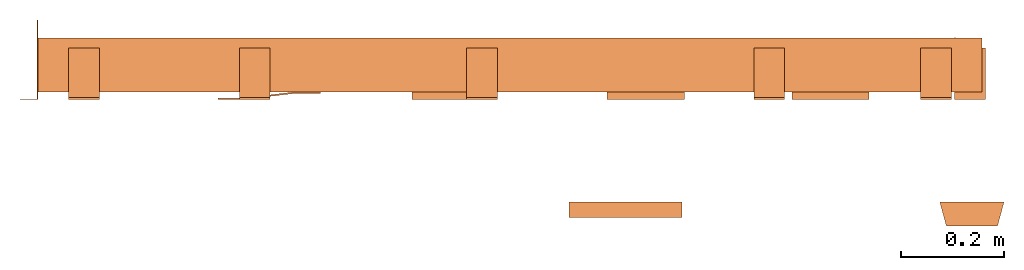
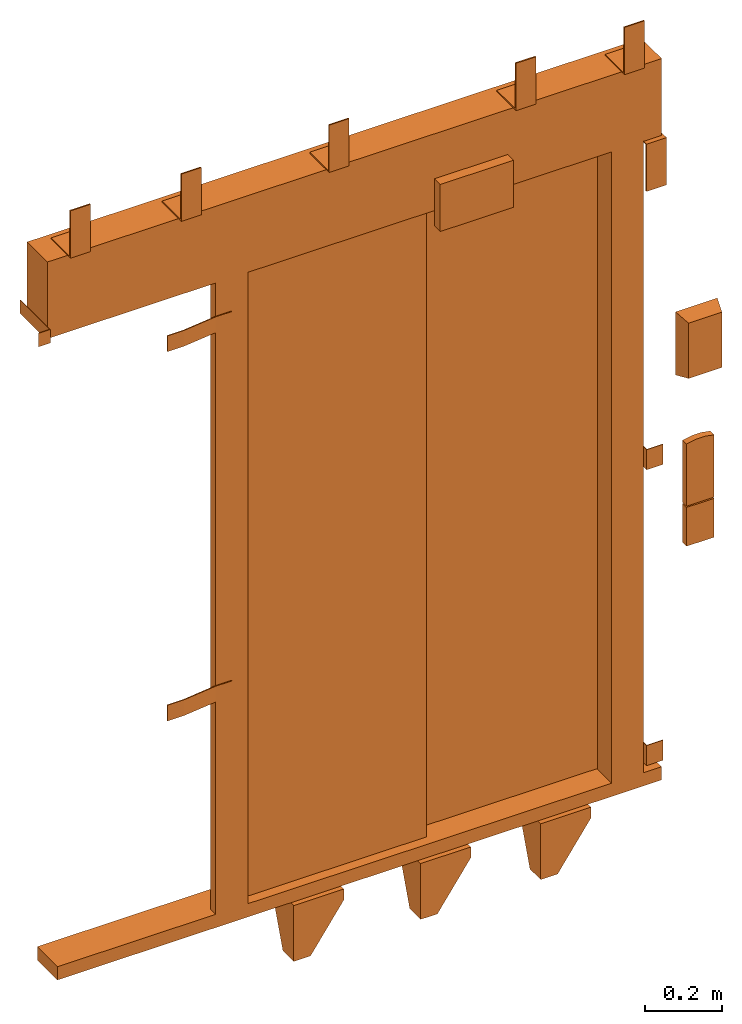
# One storey: 1 proxy.
"""IFC2X3 building model written with IfcOpenShell, lengths in millimetres."""

from ifc_helpers import new_model, entity, si_unit, converted_unit, derived_unit, direction, frame, origin, place, context, subcontext, project, spatial, faceted_brep, source, transform, mapped, material, type_object, type_shapes, element, save


model = new_model("IFC2X3")

# Units and contexts
model_context = context("Model", 3, precision=0.01, world=origin(), true_north=direction((6.12303176911189e-17, 1.0)))
body_context = subcontext(model_context, "Body", "Model", "MODEL_VIEW")
ifc_project = project(units=[si_unit("LENGTHUNIT", "METRE", prefix="MILLI"), si_unit("AREAUNIT", "SQUARE_METRE"), si_unit("VOLUMEUNIT", "CUBIC_METRE"), converted_unit("PLANEANGLEUNIT", "DEGREE", entity("IfcRatioMeasure", 0.0174532925199433), si_unit("PLANEANGLEUNIT", "RADIAN"), dimensions=[0, 0, 0, 0, 0, 0, 0]), si_unit("MASSUNIT", "GRAM", prefix="KILO"), derived_unit("MASSDENSITYUNIT", [(si_unit("MASSUNIT", "GRAM", prefix="KILO"), 1), (si_unit("LENGTHUNIT", "METRE"), -3)]), derived_unit("MOMENTOFINERTIAUNIT", [(si_unit("LENGTHUNIT", "METRE"), 4)]), si_unit("TIMEUNIT", "SECOND"), si_unit("FREQUENCYUNIT", "HERTZ"), si_unit("THERMODYNAMICTEMPERATUREUNIT", "DEGREE_CELSIUS"), derived_unit("THERMALTRANSMITTANCEUNIT", [(si_unit("MASSUNIT", "GRAM", prefix="KILO"), 1), (si_unit("THERMODYNAMICTEMPERATUREUNIT", "KELVIN"), -1), (si_unit("TIMEUNIT", "SECOND"), -3)]), derived_unit("VOLUMETRICFLOWRATEUNIT", [(si_unit("LENGTHUNIT", "METRE"), 3), (si_unit("TIMEUNIT", "SECOND"), -1)]), derived_unit("MASSFLOWRATEUNIT", [(si_unit("MASSUNIT", "GRAM", prefix="KILO"), 1), (si_unit("TIMEUNIT", "SECOND"), -1)]), derived_unit("ROTATIONALFREQUENCYUNIT", [(si_unit("TIMEUNIT", "SECOND"), -1)]), si_unit("ELECTRICCURRENTUNIT", "AMPERE"), si_unit("ELECTRICVOLTAGEUNIT", "VOLT"), si_unit("POWERUNIT", "WATT"), si_unit("FORCEUNIT", "NEWTON", prefix="KILO"), si_unit("ILLUMINANCEUNIT", "LUX"), si_unit("LUMINOUSFLUXUNIT", "LUMEN"), si_unit("LUMINOUSINTENSITYUNIT", "CANDELA"), derived_unit("USERDEFINED", [(si_unit("MASSUNIT", "GRAM", prefix="KILO"), -1), (si_unit("LENGTHUNIT", "METRE"), -2), (si_unit("TIMEUNIT", "SECOND"), 3), (si_unit("LUMINOUSFLUXUNIT", "LUMEN"), 1)]), derived_unit("LINEARVELOCITYUNIT", [(si_unit("LENGTHUNIT", "METRE"), 1), (si_unit("TIMEUNIT", "SECOND"), -1)]), si_unit("PRESSUREUNIT", "PASCAL"), derived_unit("USERDEFINED", [(si_unit("LENGTHUNIT", "METRE"), -2), (si_unit("MASSUNIT", "GRAM", prefix="KILO"), 1), (si_unit("TIMEUNIT", "SECOND"), -2)]), derived_unit("LINEARFORCEUNIT", [(si_unit("MASSUNIT", "GRAM", prefix="KILO"), 1), (si_unit("LENGTHUNIT", "METRE"), 1), (si_unit("TIMEUNIT", "SECOND"), -2), (si_unit("LENGTHUNIT", "METRE"), -1)]), derived_unit("PLANARFORCEUNIT", [(si_unit("MASSUNIT", "GRAM", prefix="KILO"), 1), (si_unit("LENGTHUNIT", "METRE"), 1), (si_unit("TIMEUNIT", "SECOND"), -2), (si_unit("LENGTHUNIT", "METRE"), -2)])], contexts=[model_context])

# Site, building, storey
site_placement = place(None, origin())
site = spatial("IfcSite", under=ifc_project, at=site_placement, CompositionType="ELEMENT")
building_placement = place(site_placement, origin())
building = spatial("IfcBuilding", under=site, at=building_placement, CompositionType="ELEMENT")
storey_placement = place(building_placement, frame((0.0, 0.0, 24000.0)))
storey = spatial("IfcBuildingStorey", under=building, at=storey_placement, CompositionType="ELEMENT", Elevation=24000.0)

# Proxy
ifc_material = material()
building_element_proxy_type = type_object("IfcBuildingElementProxyType", PredefinedType="NOTDEFINED", material=ifc_material)
shared_shape = source(origin(), body_context, "Body", "Brep", [
    faceted_brep([(11.67, 105.0, -47.0), (114.5, 33.0, -47.0), (114.5, 5.0, -47.0), (-31.0, 5.0, -47.0), (-31.0, 105.0, -47.0), (11.67, 105.0, -42.0), (-36.0, 105.0, -42.0), (-36.0, 0.0, -42.0), (114.5, 0.0, -42.0), (114.5, 33.0, -42.0), (-31.0, 105.0, -84.0), (-36.0, 105.0, -84.0), (-36.0, 55.86, -219.0), (-36.0, 0.0, -219.0), (114.5, 0.0, -76.19), (114.5, 5.0, -76.19), (14.5, 5.0, -219.0), (-31.0, 5.0, -219.0), (14.5, 0.0, -219.0), (-31.0, 55.86, -219.0)], [[[0, 1, 2, 3, 4]], [[5, 6, 7, 8, 9]], [[6, 5, 0, 4, 10, 11]], [[6, 11, 12, 13, 7]], [[2, 1, 9, 8, 14, 15]], [[1, 0, 5, 9]], [[15, 16, 17, 3, 2]], [[7, 13, 18, 14, 8]], [[16, 15, 14, 18]], [[18, 13, 12, 19, 17, 16]], [[19, 10, 4, 3, 17]], [[12, 11, 10, 19]]]),
    faceted_brep([(-1180.19, 1.5, 2038.5), (-1180.19, 0.0, 2038.5), (-1145.19, 0.0, 2038.5), (-1145.19, 155.0, 2038.5), (-1146.69, 155.0, 2038.5), (-1146.69, 1.5, 2038.5), (-1180.19, 1.5, 1995.5), (-1146.69, 1.5, 1995.5), (-1146.69, 155.0, 1995.5), (-1145.19, 155.0, 1995.5), (-1145.19, 0.0, 1995.5), (-1180.19, 0.0, 1995.5)], [[[0, 1, 2, 3, 4, 5]], [[6, 7, 8, 9, 10, 11]], [[1, 0, 6, 11]], [[2, 1, 11, 10]], [[3, 2, 10, 9]], [[4, 3, 9, 8]], [[5, 4, 8, 7]], [[0, 5, 7, 6]]]),
    faceted_brep([(-794.09, 3.0, 1895.0), (-794.09, 0.0, 1895.0), (-744.09, 0.0, 1895.0), (-644.09, 12.0, 1895.0), (-594.09, 12.0, 1895.0), (-594.09, 15.0, 1895.0), (-644.09, 15.0, 1895.0), (-744.09, 3.0, 1895.0), (-794.09, 3.0, 1845.0), (-744.09, 3.0, 1845.0), (-644.09, 15.0, 1845.0), (-594.09, 15.0, 1845.0), (-594.09, 12.0, 1845.0), (-644.09, 12.0, 1845.0), (-744.09, 0.0, 1845.0), (-794.09, 0.0, 1845.0)], [[[0, 1, 2, 3, 4, 5, 6, 7]], [[8, 9, 10, 11, 12, 13, 14, 15]], [[1, 0, 8, 15]], [[2, 1, 15, 14]], [[3, 2, 14, 13]], [[4, 3, 13, 12]], [[5, 4, 12, 11]], [[6, 5, 11, 10]], [[7, 6, 10, 9]], [[0, 7, 9, 8]]]),
    faceted_brep([(-794.09, 3.0, 725.0), (-794.09, 0.0, 725.0), (-744.09, 0.0, 725.0), (-644.09, 12.0, 725.0), (-594.09, 12.0, 725.0), (-594.09, 15.0, 725.0), (-644.09, 15.0, 725.0), (-744.09, 3.0, 725.0), (-794.09, 3.0, 675.0), (-744.09, 3.0, 675.0), (-644.09, 15.0, 675.0), (-594.09, 15.0, 675.0), (-594.09, 12.0, 675.0), (-644.09, 12.0, 675.0), (-744.09, 0.0, 675.0), (-794.09, 0.0, 675.0)], [[[0, 1, 2, 3, 4, 5, 6, 7]], [[8, 9, 10, 11, 12, 13, 14, 15]], [[1, 0, 8, 15]], [[2, 1, 15, 14]], [[3, 2, 14, 13]], [[4, 3, 13, 12]], [[5, 4, 12, 11]], [[6, 5, 11, 10]], [[7, 6, 10, 9]], [[0, 7, 9, 8]]]),
    faceted_brep([(641.09, 121.0, 95.0), (641.09, 0.0, 95.0), (691.09, 0.0, 95.0), (691.09, 2.0, 95.0), (643.09, 2.0, 95.0), (643.09, 121.0, 95.0), (641.09, 121.0, 31.0), (643.09, 121.0, 31.0), (643.09, 2.0, 31.0), (691.09, 2.0, 31.0), (691.09, 0.0, 31.0), (641.09, 0.0, 31.0)], [[[0, 1, 2, 3, 4, 5]], [[6, 7, 8, 9, 10, 11]], [[1, 0, 6, 11]], [[2, 1, 11, 10]], [[3, 2, 10, 9]], [[4, 3, 9, 8]], [[5, 4, 8, 7]], [[0, 5, 7, 6]]]),
    faceted_brep([(641.09, 121.0, 1032.0), (641.09, 0.0, 1032.0), (691.09, 0.0, 1032.0), (691.09, 2.0, 1032.0), (643.09, 2.0, 1032.0), (643.09, 121.0, 1032.0), (641.09, 121.0, 968.0), (643.09, 121.0, 968.0), (643.09, 2.0, 968.0), (691.09, 2.0, 968.0), (691.09, 0.0, 968.0), (641.09, 0.0, 968.0)], [[[0, 1, 2, 3, 4, 5]], [[6, 7, 8, 9, 10, 11]], [[1, 0, 6, 11]], [[2, 1, 11, 10]], [[3, 2, 10, 9]], [[4, 3, 9, 8]], [[5, 4, 8, 7]], [[0, 5, 7, 6]]]),
    faceted_brep([(371.77, 105.0, -47.0), (474.59, 33.0, -47.0), (474.59, 5.0, -47.0), (329.09, 5.0, -47.0), (329.09, 105.0, -47.0), (371.77, 105.0, -42.0), (324.09, 105.0, -42.0), (324.09, 0.0, -42.0), (474.59, 0.0, -42.0), (474.59, 33.0, -42.0), (329.09, 105.0, -84.0), (324.09, 105.0, -84.0), (324.09, 55.86, -219.0), (324.09, 0.0, -219.0), (474.59, 0.0, -76.19), (474.59, 5.0, -76.19), (374.59, 5.0, -219.0), (329.09, 5.0, -219.0), (374.59, 0.0, -219.0), (329.09, 55.86, -219.0)], [[[0, 1, 2, 3, 4]], [[5, 6, 7, 8, 9]], [[6, 5, 0, 4, 10, 11]], [[6, 11, 12, 13, 7]], [[2, 1, 9, 8, 14, 15]], [[1, 0, 5, 9]], [[15, 16, 17, 3, 2]], [[7, 13, 18, 14, 8]], [[16, 15, 14, 18]], [[18, 13, 12, 19, 17, 16]], [[19, 10, 4, 3, 17]], [[12, 11, 10, 19]]]),
    faceted_brep([(-368.42, 105.0, -47.0), (-265.59, 33.0, -47.0), (-265.59, 5.0, -47.0), (-411.09, 5.0, -47.0), (-411.09, 105.0, -47.0), (-368.42, 105.0, -42.0), (-416.09, 105.0, -42.0), (-416.09, 0.0, -42.0), (-265.59, 0.0, -42.0), (-265.59, 33.0, -42.0), (-411.09, 105.0, -84.0), (-416.09, 105.0, -84.0), (-416.09, 55.86, -219.0), (-416.09, 0.0, -219.0), (-265.59, 0.0, -76.19), (-265.59, 5.0, -76.19), (-365.59, 5.0, -219.0), (-411.09, 5.0, -219.0), (-365.59, 0.0, -219.0), (-411.09, 55.86, -219.0)], [[[0, 1, 2, 3, 4]], [[5, 6, 7, 8, 9]], [[6, 5, 0, 4, 10, 11]], [[6, 11, 12, 13, 7]], [[2, 1, 9, 8, 14, 15]], [[1, 0, 5, 9]], [[15, 16, 17, 3, 2]], [[7, 13, 18, 14, 8]], [[16, 15, 14, 18]], [[18, 13, 12, 19, 17, 16]], [[19, 10, 4, 3, 17]], [[12, 11, 10, 19]]]),
    faceted_brep([(701.09, 100.0, 2000.0), (701.09, 0.0, 2000.0), (701.09, 0.0, 1850.0), (701.09, 4.0, 1850.0), (701.09, 4.0, 1996.0), (701.09, 100.0, 1996.0), (641.09, 100.0, 2000.0), (641.09, 100.0, 1996.0), (641.09, 4.0, 1996.0), (641.09, 4.0, 1850.0), (641.09, 0.0, 1850.0), (641.09, 0.0, 2000.0)], [[[0, 1, 2, 3, 4, 5]], [[6, 7, 8, 9, 10, 11]], [[1, 0, 6, 11]], [[2, 1, 11, 10]], [[3, 2, 10, 9]], [[4, 3, 9, 8]], [[5, 4, 8, 7]], [[0, 5, 7, 6]]]),
    faceted_brep([(635.09, 100.0, 2247.0), (635.09, 4.0, 2247.0), (635.09, 4.0, 2393.0), (635.09, 0.0, 2393.0), (635.09, 0.0, 2243.0), (635.09, 100.0, 2243.0), (575.09, 100.0, 2247.0), (575.09, 100.0, 2243.0), (575.09, 0.0, 2243.0), (575.09, 0.0, 2393.0), (575.09, 4.0, 2393.0), (575.09, 4.0, 2247.0)], [[[0, 1, 2, 3, 4, 5]], [[6, 7, 8, 9, 10, 11]], [[1, 0, 6, 11]], [[2, 1, 11, 10]], [[3, 2, 10, 9]], [[4, 3, 9, 8]], [[5, 4, 8, 7]], [[0, 5, 7, 6]]]),
    faceted_brep([(-250.0, 100.0, 2247.0), (-250.0, 4.0, 2247.0), (-250.0, 4.0, 2393.0), (-250.0, 0.0, 2393.0), (-250.0, 0.0, 2243.0), (-250.0, 100.0, 2243.0), (-310.0, 100.0, 2247.0), (-310.0, 100.0, 2243.0), (-310.0, 0.0, 2243.0), (-310.0, 0.0, 2393.0), (-310.0, 4.0, 2393.0), (-310.0, 4.0, 2247.0)], [[[0, 1, 2, 3, 4, 5]], [[6, 7, 8, 9, 10, 11]], [[1, 0, 6, 11]], [[2, 1, 11, 10]], [[3, 2, 10, 9]], [[4, 3, 9, 8]], [[5, 4, 8, 7]], [[0, 5, 7, 6]]]),
    faceted_brep([(-692.5, 100.0, 2247.0), (-692.5, 4.0, 2247.0), (-692.5, 4.0, 2393.0), (-692.5, 0.0, 2393.0), (-692.5, 0.0, 2243.0), (-692.5, 100.0, 2243.0), (-752.5, 100.0, 2247.0), (-752.5, 100.0, 2243.0), (-752.5, 0.0, 2243.0), (-752.5, 0.0, 2393.0), (-752.5, 4.0, 2393.0), (-752.5, 4.0, 2247.0)], [[[0, 1, 2, 3, 4, 5]], [[6, 7, 8, 9, 10, 11]], [[1, 0, 6, 11]], [[2, 1, 11, 10]], [[3, 2, 10, 9]], [[4, 3, 9, 8]], [[5, 4, 8, 7]], [[0, 5, 7, 6]]]),
    faceted_brep([(-1025.19, 100.0, 2247.0), (-1025.19, 4.0, 2247.0), (-1025.19, 4.0, 2393.0), (-1025.19, 0.0, 2393.0), (-1025.19, 0.0, 2243.0), (-1025.19, 100.0, 2243.0), (-1085.19, 100.0, 2247.0), (-1085.19, 100.0, 2243.0), (-1085.19, 0.0, 2243.0), (-1085.19, 0.0, 2393.0), (-1085.19, 4.0, 2393.0), (-1085.19, 4.0, 2247.0)], [[[0, 1, 2, 3, 4, 5]], [[6, 7, 8, 9, 10, 11]], [[1, 0, 6, 11]], [[2, 1, 11, 10]], [[3, 2, 10, 9]], [[4, 3, 9, 8]], [[5, 4, 8, 7]], [[0, 5, 7, 6]]]),
    faceted_brep([(310.0, 100.0, 2247.0), (310.0, 4.0, 2247.0), (310.0, 4.0, 2393.0), (310.0, 0.0, 2393.0), (310.0, 0.0, 2243.0), (310.0, 100.0, 2243.0), (250.0, 100.0, 2247.0), (250.0, 100.0, 2243.0), (250.0, 0.0, 2243.0), (250.0, 0.0, 2393.0), (250.0, 4.0, 2393.0), (250.0, 4.0, 2247.0)], [[[0, 1, 2, 3, 4, 5]], [[6, 7, 8, 9, 10, 11]], [[1, 0, 6, 11]], [[2, 1, 11, 10]], [[3, 2, 10, 9]], [[4, 3, 9, 8]], [[5, 4, 8, 7]], [[0, 5, 7, 6]]]),
    faceted_brep([(725.09, -246.0, 1587.5), (625.09, -246.0, 1587.5), (625.09, -246.0, 1412.5), (725.09, -246.0, 1412.5), (737.59, -200.0, 1600.0), (737.59, -200.0, 1400.0), (612.59, -200.0, 1400.0), (612.59, -200.0, 1600.0)], [[[0, 1, 2, 3]], [[4, 5, 6, 7]], [[4, 7, 1, 0]], [[7, 6, 2, 1]], [[6, 5, 3, 2]], [[5, 4, 0, 3]]]),
    faceted_brep([(716.59, -220.0, 985.0), (633.59, -220.0, 985.0), (633.59, -220.0, 862.0), (716.59, -220.0, 862.0), (716.59, -200.0, 985.0), (716.59, -200.0, 862.0), (633.59, -200.0, 862.0), (633.59, -200.0, 985.0)], [[[0, 1, 2, 3]], [[4, 5, 6, 7]], [[1, 0, 4, 7]], [[2, 1, 7, 6]], [[3, 2, 6, 5]], [[0, 3, 5, 4]]]),
    faceted_brep([(110.0, -200.0, 2274.5), (110.0, -200.0, 2125.5), (-110.0, -200.0, 2125.5), (-110.0, -200.0, 2274.5), (110.0, -230.0, 2274.5), (-110.0, -230.0, 2274.5), (-110.0, -230.0, 2125.5), (110.0, -230.0, 2125.5)], [[[0, 1, 2, 3]], [[4, 5, 6, 7]], [[5, 4, 0, 3]], [[6, 5, 3, 2]], [[7, 6, 2, 1]], [[4, 7, 1, 0]]]),
    faceted_brep([(689.09, -220.0, 1191.35), (661.1, -220.0, 1191.35), (633.59, -220.0, 1186.14), (633.59, -220.0, 989.0), (716.59, -220.0, 989.0), (716.59, -220.0, 1186.14), (716.59, -200.0, 1186.14), (716.59, -200.0, 989.0), (633.59, -200.0, 989.0), (633.59, -200.0, 1186.14), (661.1, -200.0, 1191.35), (689.09, -200.0, 1191.35)], [[[0, 1, 2, 3, 4, 5]], [[6, 7, 8, 9, 10, 11]], [[3, 2, 9, 8]], [[4, 3, 8, 7]], [[5, 4, 7, 6]], [[6, 11, 0, 5]], [[11, 10, 1, 0]], [[10, 9, 2, 1]]]),
    faceted_brep([(545.09, 87.0, 2000.0), (545.09, 15.0, 2000.0), (641.09, 15.0, 2000.0), (641.09, 120.0, 2000.0), (564.09, 120.0, 2000.0), (564.09, 87.0, 2000.0), (545.09, 87.0, 0.0), (545.09, 15.0, 0.0), (641.09, 15.0, 0.0), (641.09, 120.0, 0.0), (564.09, 120.0, 0.0), (564.09, 87.0, 0.0)], [[[0, 1, 2, 3, 4, 5]], [[1, 0, 6, 7]], [[2, 1, 7, 8]], [[3, 2, 8, 9]], [[4, 3, 9, 10]], [[5, 4, 10, 11]], [[0, 5, 11, 6]], [[6, 11, 10, 9, 8, 7]]]),
    faceted_brep([(-545.09, 41.0, 0.0), (-545.09, 15.0, 0.0), (-641.09, 15.0, 0.0), (-641.09, 41.0, 0.0), (-641.09, 41.0, 2000.0), (-545.09, 41.0, 2000.0), (-641.09, 15.0, 2000.0), (-545.09, 15.0, 2000.0)], [[[0, 1, 2, 3]], [[4, 5, 0, 3]], [[6, 4, 3, 2]], [[7, 6, 2, 1]], [[5, 7, 1, 0]], [[5, 4, 6, 7]]]),
    faceted_brep([(695.09, 15.0, 0.0), (695.09, 15.0, -42.0), (695.09, 120.0, -42.0), (695.09, 120.0, 0.0), (-1115.19, 15.0, 0.0), (-1115.19, 120.0, 0.0), (-1115.19, 120.0, -42.0), (-1115.19, 15.0, -42.0)], [[[0, 1, 2, 3]], [[4, 5, 6, 7]], [[1, 0, 4, 7]], [[2, 1, 7, 6]], [[3, 2, 6, 5]], [[0, 3, 5, 4]]]),
    faceted_brep([(695.09, 15.0, 2243.0), (695.09, 15.0, 2000.0), (695.09, 120.0, 2000.0), (695.09, 120.0, 2243.0), (-1145.19, 15.0, 2243.0), (-1145.19, 120.0, 2243.0), (-1145.19, 120.0, 2000.0), (-1145.19, 15.0, 2000.0)], [[[0, 1, 2, 3]], [[4, 5, 6, 7]], [[1, 0, 4, 7]], [[2, 1, 7, 6]], [[3, 2, 6, 5]], [[0, 3, 5, 4]]]),
    faceted_brep([(560.09, 120.0, 2000.0), (-22.0, 120.0, 2000.0), (-22.0, 91.0, 2000.0), (560.09, 91.0, 2000.0), (560.09, 120.0, 0.0), (-22.0, 120.0, 0.0), (-22.0, 91.0, 0.0), (560.09, 91.0, 0.0)], [[[0, 1, 2, 3]], [[1, 0, 4, 5]], [[2, 1, 5, 6]], [[3, 2, 6, 7]], [[0, 3, 7, 4]], [[4, 7, 6, 5]]]),
    faceted_brep([(8.0, 87.0, 0.0), (8.0, 45.0, 0.0), (-575.09, 45.0, 0.0), (-575.09, 87.0, 0.0), (-575.09, 87.0, 2000.0), (8.0, 87.0, 2000.0), (-575.09, 45.0, 2000.0), (8.0, 45.0, 2000.0)], [[[0, 1, 2, 3]], [[4, 5, 0, 3]], [[6, 4, 3, 2]], [[7, 6, 2, 1]], [[5, 7, 1, 0]], [[5, 4, 6, 7]]]),
])
type_shapes(building_element_proxy_type, [shared_shape])
proxy_placement = place(storey_placement, frame((70118.15, 14140.0, 0.0)))
element("IfcBuildingElementProxy", 1, at=proxy_placement, inside=storey, type_object=building_element_proxy_type, material=ifc_material, context=body_context, shape_type="MappedRepresentation", body=[
    mapped(shared_shape, transform((0.0, 0.0, 0.0), scale=1.0)),
])

save(model, "model.ifc")
